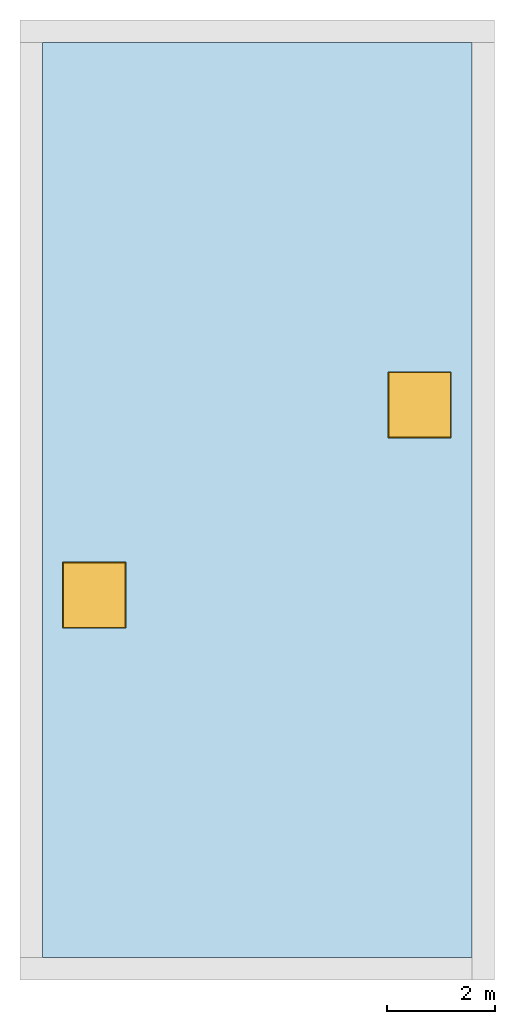
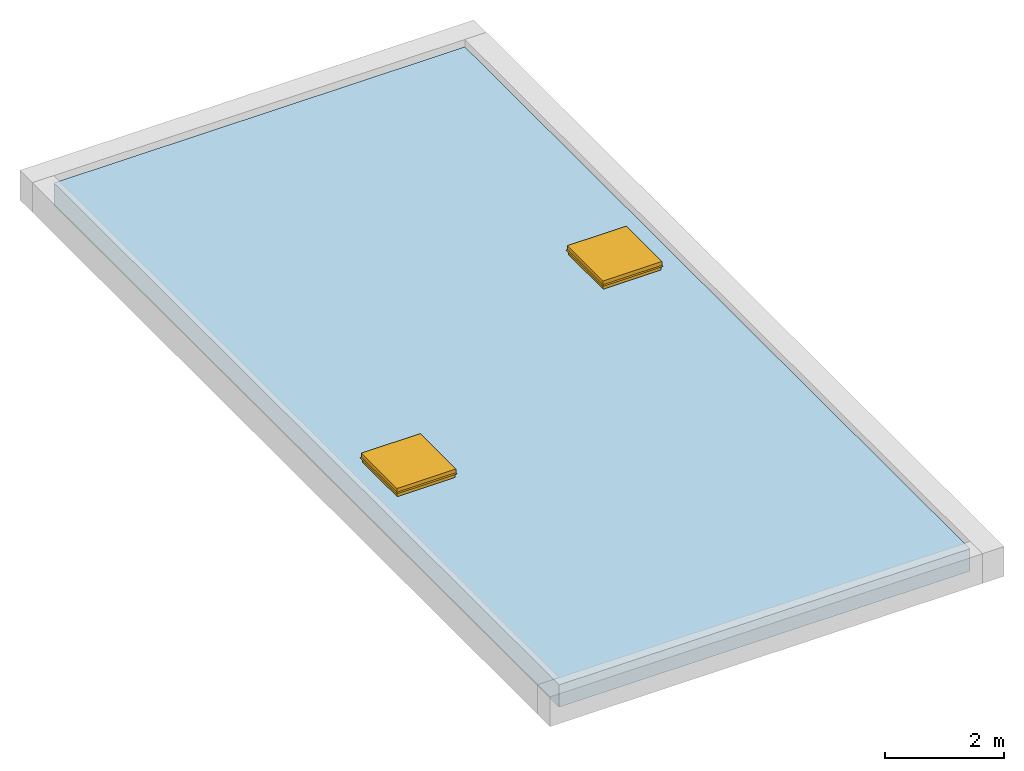
# One storey, part 2 of 2: 2 windows, 1 slab, 4 openings, 1 element without a shape of its own.
"""IFC2X3 building model written with IfcOpenShell, lengths in metres."""

from ifc_helpers import new_model, entity, si_unit, converted_unit, frame, origin, origin_2d_with_axis, place, context, project, spatial, rectangle, extrude, face_set, surface_model, source, transform, mapped, material, layer, layer_set, layer_usage, type_object, type_shapes, element, fill, aggregate, save


model = new_model("IFC2X3")

# Units and contexts
model_context = context("Model", 3, precision=1e-09, world=origin())
plan_context = context("Plan", 3, precision=1e-09, world=origin())
ifc_project = project(units=[si_unit("LENGTHUNIT", "METRE"), si_unit("AREAUNIT", "SQUARE_METRE"), si_unit("VOLUMEUNIT", "CUBIC_METRE"), converted_unit("PLANEANGLEUNIT", "DEGREE", entity("IfcRatioMeasure", 0.01745329251994328), si_unit("PLANEANGLEUNIT", "RADIAN"), dimensions=[0, 0, 0, 0, 0, 0, 0]), si_unit("TIMEUNIT", "SECOND")], contexts=[model_context, plan_context])

# Site, building, storey
site_placement = place(None, origin())
site = spatial("IfcSite", under=ifc_project, at=site_placement, CompositionType="ELEMENT")
building_placement = place(site_placement, origin())
building = spatial("IfcBuilding", under=site, at=building_placement, CompositionType="ELEMENT")
storey_placement = place(building_placement, frame((0.0, 0.0, 6.0)))
storey = spatial("IfcBuildingStorey", under=building, at=storey_placement, Name="Roof", CompositionType="ELEMENT", Elevation=6.00000000000039)

# Roof, openings, slab, windows
ifc_material_1 = material(Name="Site - Grass")
ifc_layer_1 = layer(ifc_material_1, 0.06399999999999999)
ifc_material_2 = material(Name="Roofing - Barrier")
ifc_layer_2 = layer(ifc_material_2, 0.006)
ifc_material_3 = material(Name="Roofing - EPDM Membrane")
ifc_layer_3 = layer(ifc_material_3, 0.006)
ifc_material_4 = material(Name="Insulation / Thermal Barriers - Rigid insulation")
ifc_layer_4 = layer(ifc_material_4, 0.07599999999999998)
ifc_material_5 = material(Name="Wood - Sheathing - plywood")
ifc_layer_5 = layer(ifc_material_5, 0.019)
ifc_material_6 = material(Name="Wood - Dimensional Lumber")
ifc_layer_6 = layer(ifc_material_6, 0.286)
ifc_layer_set = layer_set([ifc_layer_1, ifc_layer_2, ifc_layer_3, ifc_layer_4, ifc_layer_5, ifc_layer_6])
ifc_layer_usage = layer_usage(ifc_layer_set, "AXIS3", "NEGATIVE", 0.0)
roof_placement = place(storey_placement, origin())
roof = element("IfcRoof", 1, at=roof_placement, inside=storey, material=ifc_layer_usage, ShapeType="NOTDEFINED")
opening_1_placement = place(roof_placement, frame((0.416999999999999, -17.383, 0.0)))
opening_1 = element("IfcOpeningElement", 2, at=opening_1_placement, cuts=roof, ObjectType="Opening", context=model_context, shape_type="SweptSolid", body=[
    extrude(rectangle(XDim=1.0291, YDim=1.081099999999959, at=origin_2d_with_axis()), frame((6.992000000000032, 10.24799999999997, -1.067000000000001), z_axis=(0.0, 0.0, 1.0), x_axis=(-1.0, 0.0, 0.0)), (0.0, 0.0, 1.0), 3.048),
])
opening_2_placement = place(roof_placement, frame((0.416999999999999, -17.383, 0.0)))
opening_2 = element("IfcOpeningElement", 3, at=opening_2_placement, cuts=roof, ObjectType="Opening", context=model_context, shape_type="SweptSolid", body=[
    extrude(rectangle(XDim=1.029099999999999, YDim=1.081099999999958, at=origin_2d_with_axis()), frame((0.9590000000000255, 6.717999999999982, -1.067000000000001), z_axis=(0.0, 0.0, 1.0), x_axis=(-1.0, 0.0, 0.0)), (0.0, 0.0, 1.0), 3.048),
])
slab_placement = place(roof_placement, frame((0.416999999999999, -17.383, 0.0)))
slab = element("IfcSlab", 4, at=slab_placement, PredefinedType="ROOF", context=model_context, shape_type="SweptSolid", body=[
    extrude(rectangle(XDim=7.965999999999998, YDim=16.96599999999997, at=origin_2d_with_axis()), frame((3.983000000000001, 8.482999999999999, 0.0)), (0.0, 0.0, 1.0), 0.4570000000000001),
])
opening_3_placement = place(roof_placement, frame((1.376000000000025, -10.66500000000002, 0.0)))
element("IfcOpeningElement", 5, at=opening_3_placement, cuts=slab, ObjectType="Opening", context=model_context, shape_type="SweptSolid", body=[
    extrude(rectangle(XDim=1.0291, YDim=1.08109999999996, at=origin_2d_with_axis()), frame((0.0, 0.0, 0.0), z_axis=(0.0, 0.0, 1.0), x_axis=(-1.0, 0.0, 0.0)), (0.0, 0.0, 1.0), 0.4570000000000001),
])
opening_4_placement = place(roof_placement, frame((7.409000000000029, -7.135000000000028, 0.0)))
element("IfcOpeningElement", 6, at=opening_4_placement, cuts=slab, ObjectType="Opening", context=model_context, shape_type="SweptSolid", body=[
    extrude(rectangle(XDim=1.029099999999999, YDim=1.08109999999996, at=origin_2d_with_axis()), frame((0.0, 0.0, 0.0), z_axis=(0.0, 0.0, 1.0), x_axis=(-1.0, 0.0, 0.0)), (0.0, 0.0, 1.0), 0.4570000000000001),
])
aggregate(roof, [slab])
window_style = type_object("IfcWindowStyle", Name="1180 x 1170mm", ConstructionType="NOTDEFINED", OperationType="NOTDEFINED", ParameterTakesPrecedence=False, Sizeable=False)
shared_shape = source(origin(), model_context, "Body", "SurfaceModel", [
    surface_model("IfcFaceBasedSurfaceModel", [(0.2544400730277169, 0.3701040988119702, 4.267), (0.2798400730277391, 0.3955040988119924, 4.267), (0.2798400730277391, -0.7744959011880403, 4.267), (0.254440073027717, -0.7490959011880184, 4.267), (0.2544400730277169, 0.3701040988119703, 4.292400000000001), (0.2544400730277168, -0.7490959011880184, 4.292400000000001), (0.292540073027718, 0.4082040988119711, 4.292400000000001), (0.2925400730277178, -0.7871959011880192, 4.292400000000001), (0.2925400730277178, 0.4082040988119711, 4.267), (0.2925400730277178, -0.7871959011880192, 4.267), (0.2925400730277178, 0.4082040988119711, 4.216200000000001), (0.2925400730277178, -0.7871959011880192, 4.216200000000001), (0.3071089145110343, 0.4227729402952876, 4.19539353807506), (0.3071089145110343, -0.8017647426713357, 4.19539353807506), (0.3019072990297992, 0.4175713248140525, 4.191751327704231), (0.3019072990297992, -0.7965631271901006, 4.191751327704231), (0.286190073027718, 0.4018540988119712, 4.214197852690619), (0.286190073027718, -0.7808459011880192, 4.214197852690619), (0.2861900730277179, 0.4018540988119712, 4.267), (0.286190073027718, -0.7808459011880192, 4.267), (-0.8381599269722575, -0.7744959011880405, 4.267), (-0.8127599269722353, -0.7490959011880184, 4.267), (-0.8127599269722353, -0.7490959011880182, 4.292400000000001), (-0.8508599269722361, -0.7871959011880192, 4.292400000000001), (-0.8508599269722361, -0.7871959011880192, 4.267), (-0.8508599269722361, -0.7871959011880192, 4.216200000000001), (-0.8654287684555526, -0.8017647426713357, 4.19539353807506), (-0.8602271529743175, -0.7965631271901006, 4.191751327704231), (-0.8445099269722363, -0.7808459011880192, 4.214197852690619), (-0.8445099269722363, -0.7808459011880192, 4.267), (-0.8381599269722575, 0.3955040988119924, 4.267), (-0.8127599269722353, 0.3701040988119703, 4.267), (-0.8127599269722353, 0.3701040988119703, 4.292400000000001), (-0.8508599269722361, 0.4082040988119711, 4.292400000000001), (-0.8508599269722361, 0.4082040988119711, 4.267), (-0.8508599269722361, 0.4082040988119711, 4.216200000000001), (-0.8654287684555526, 0.4227729402952877, 4.19539353807506), (-0.8602271529743175, 0.4175713248140525, 4.191751327704231), (-0.8445099269722363, 0.4018540988119712, 4.214197852690619), (-0.8445099269722363, 0.4018540988119712, 4.267), (0.279840073027754, -0.7744959011880286, 4.267), (0.279840073027754, -0.7744959011880286, 4.1146), (0.2798400730277539, 0.3955040988119715, 4.1146), (0.2798400730277539, 0.3955040988119716, 4.267), (0.2544400730277538, -0.7490959011880284, 4.267), (0.2544400730277538, 0.3701040988119714, 4.267), (0.2544400730277538, -0.7490959011880284, 4.2416), (0.2544400730277538, 0.3701040988119714, 4.2416), (0.2353900730277543, -0.7300459011880289, 4.2416), (0.2353900730277543, 0.351054098811972, 4.2416), (0.2353900730277543, -0.7300459011880289, 4.1146), (0.2353900730277543, 0.351054098811972, 4.1146), (-0.8381599269722712, 0.3955040988119715, 4.1146), (-0.8381599269722712, 0.3955040988119715, 4.267), (-0.812759926972271, 0.3701040988119713, 4.267), (-0.812759926972271, 0.3701040988119714, 4.2416), (-0.7937099269722715, 0.3510540988119719, 4.2416), (-0.7937099269722715, 0.3510540988119719, 4.1146), (-0.8381599269722712, -0.7744959011880286, 4.267), (-0.8381599269722712, -0.7744959011880286, 4.1146), (-0.812759926972271, -0.7490959011880284, 4.267), (-0.812759926972271, -0.7490959011880284, 4.2416), (-0.7937099269722715, -0.7300459011880289, 4.2416), (-0.7937099269722715, -0.7300459011880289, 4.1146), (0.2544400730277528, -0.7490959011880286, 4.292400000000001), (-0.8127599269722908, -0.7490959011880285, 4.292400000000001), (-0.8127599269722907, 0.3701040988119297, 4.292400000000001), (0.254440073027753, 0.3701040988119296, 4.292400000000001), (0.2544400730277528, -0.7490959011880286, 4.28605), (-0.8127599269722908, -0.7490959011880285, 4.28605), (-0.8127599269722907, 0.3701040988119297, 4.28605), (0.254440073027753, 0.3701040988119296, 4.28605)], [face_set([[[0, 1, 2, 3]], [[4, 5, 3, 0]], [[6, 7, 5, 4]], [[8, 6, 7, 9]], [[10, 8, 9, 11]], [[12, 13, 11, 10]], [[14, 12, 13, 15]], [[16, 14, 15, 17]], [[18, 19, 17, 16]], [[1, 18, 19, 2]], [[3, 2, 20, 21]], [[5, 22, 21, 3]], [[7, 23, 22, 5]], [[9, 7, 23, 24]], [[11, 9, 24, 25]], [[13, 26, 25, 11]], [[15, 13, 26, 27]], [[17, 15, 27, 28]], [[19, 29, 28, 17]], [[2, 19, 29, 20]], [[21, 20, 30, 31]], [[22, 21, 31, 32]], [[23, 33, 32, 22]], [[24, 34, 33, 23]], [[25, 35, 34, 24]], [[26, 36, 35, 25]], [[27, 26, 36, 37]], [[28, 27, 37, 38]], [[29, 28, 38, 39]], [[20, 29, 39, 30]], [[31, 30, 1, 0]], [[32, 4, 0, 31]], [[33, 6, 4, 32]], [[34, 33, 6, 8]], [[35, 34, 8, 10]], [[36, 12, 10, 35]], [[37, 36, 12, 14]], [[38, 37, 14, 16]], [[39, 18, 16, 38]], [[30, 39, 18, 1]]]), face_set([[[40, 41, 42, 43]], [[44, 45, 43, 40]], [[46, 47, 45, 44]], [[48, 49, 47, 46]], [[50, 51, 49, 48]], [[41, 50, 51, 42]], [[43, 42, 52, 53]], [[45, 54, 53, 43]], [[47, 55, 54, 45]], [[49, 56, 55, 47]], [[51, 57, 56, 49]], [[42, 51, 57, 52]], [[53, 58, 59, 52]], [[54, 60, 58, 53]], [[55, 54, 60, 61]], [[56, 62, 61, 55]], [[57, 56, 62, 63]], [[52, 57, 63, 59]], [[58, 59, 41, 40]], [[60, 44, 40, 58]], [[61, 46, 44, 60]], [[62, 48, 46, 61]], [[63, 50, 48, 62]], [[59, 63, 50, 41]]]), face_set([[[64, 65, 66, 67]], [[68, 69, 70, 71]], [[67, 64, 68, 71]], [[66, 67, 71, 70]], [[65, 69, 70, 66]], [[64, 65, 69, 68]]])]),
])
type_shapes(window_style, [shared_shape])
window_1_placement = place(opening_2_placement, frame((1.238159926972274, 6.90749590118803, -3.657600000000183)))
window_1 = element("IfcWindow", 7, at=window_1_placement, inside=storey, type_object=window_style, Name="M_Skylight:1180 x 1170mm:1180 x 1170mm", ObjectType="1180 x 1170mm", OverallHeight=0.6348000000000008, OverallWidth=1.172537682966587, context=model_context, shape_type="MappedRepresentation", body=[
    mapped(shared_shape, transform((0.0, 0.0, 0.0), scale=1.0)),
])
fill(opening_2, window_1)
window_2_placement = place(opening_1_placement, frame((7.271159926972279, 10.43749590118802, -3.657600000000183)))
window_2 = element("IfcWindow", 8, at=window_2_placement, inside=storey, type_object=window_style, Name="M_Skylight:1180 x 1170mm:1180 x 1170mm", ObjectType="1180 x 1170mm", OverallHeight=0.6348000000000008, OverallWidth=1.172537682966587, context=model_context, shape_type="MappedRepresentation", body=[
    mapped(shared_shape, transform((0.0, 0.0, 0.0), scale=1.0)),
])
fill(opening_1, window_2)

save(model, "model.ifc")
